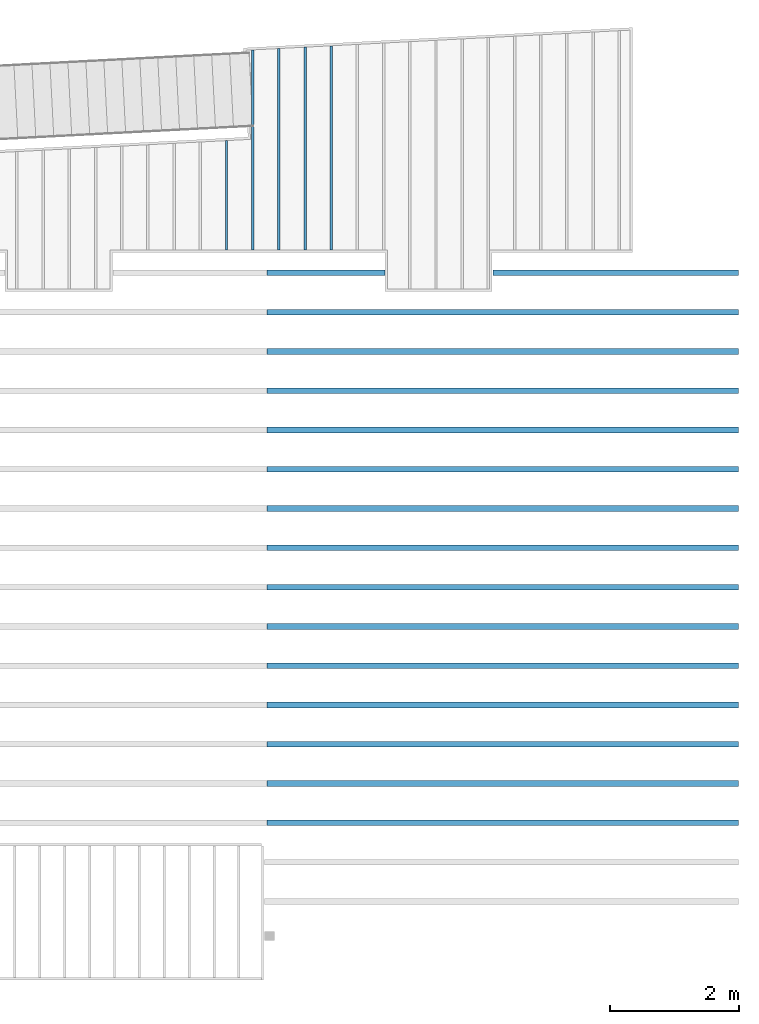
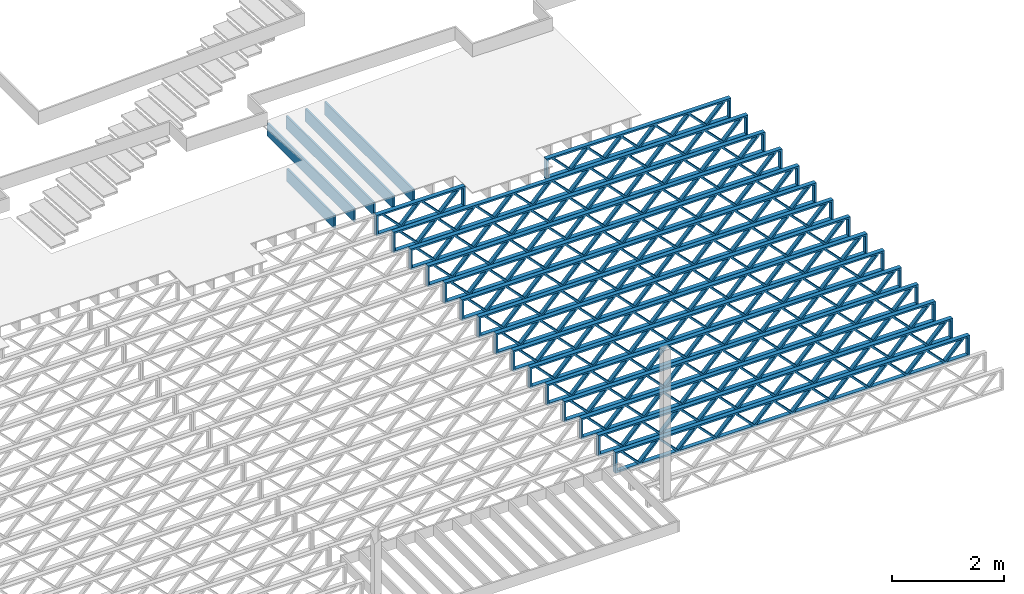
# One storey, part 11 of 23: 21 beams, 2 elements without a shape of their own.
"""IFC4 building model written with IfcOpenShell, lengths in feet."""

from ifc_helpers import new_model, entity, si_unit, converted_unit, derived_unit, direction, frame, frame_2d, origin, origin_2d_with_axis, place, context, subcontext, project, spatial, rectangle, extrude, source, transform, mapped, material, material_profile, profile_set, profile_usage, type_object, type_shapes, element, aggregate, save


model = new_model("IFC4")

# Units and contexts
model_context = context("Model", 3, precision=0.0001, world=origin(), true_north=direction((6.12303176911189e-17, 1.0)))
body_context = subcontext(model_context, "Body", "Model", "MODEL_VIEW")
ifc_project = project(units=[converted_unit("LENGTHUNIT", "FOOT", entity("IfcRatioMeasure", 0.3048), si_unit("LENGTHUNIT", "METRE"), dimensions=[1, 0, 0, 0, 0, 0, 0]), converted_unit("AREAUNIT", "SQUARE FOOT", entity("IfcRatioMeasure", 0.09290304), si_unit("AREAUNIT", "SQUARE_METRE"), dimensions=[2, 0, 0, 0, 0, 0, 0]), converted_unit("VOLUMEUNIT", "CUBIC FOOT", entity("IfcRatioMeasure", 0.028316846592), si_unit("VOLUMEUNIT", "CUBIC_METRE"), dimensions=[3, 0, 0, 0, 0, 0, 0]), converted_unit("PLANEANGLEUNIT", "DEGREE", entity("IfcRatioMeasure", 0.0174532925199433), si_unit("PLANEANGLEUNIT", "RADIAN"), dimensions=[0, 0, 0, 0, 0, 0, 0]), si_unit("MASSUNIT", "GRAM", prefix="KILO"), derived_unit("MASSDENSITYUNIT", [(si_unit("MASSUNIT", "GRAM", prefix="KILO"), 1), (si_unit("LENGTHUNIT", "METRE"), -3)]), derived_unit("MOMENTOFINERTIAUNIT", [(si_unit("LENGTHUNIT", "METRE"), 4)]), si_unit("TIMEUNIT", "SECOND"), si_unit("FREQUENCYUNIT", "HERTZ"), si_unit("THERMODYNAMICTEMPERATUREUNIT", "DEGREE_CELSIUS"), derived_unit("THERMALTRANSMITTANCEUNIT", [(si_unit("MASSUNIT", "GRAM", prefix="KILO"), 1), (si_unit("THERMODYNAMICTEMPERATUREUNIT", "KELVIN"), -1), (si_unit("TIMEUNIT", "SECOND"), -3)]), derived_unit("VOLUMETRICFLOWRATEUNIT", [(si_unit("LENGTHUNIT", "METRE"), 3), (si_unit("TIMEUNIT", "SECOND"), -1)]), si_unit("ELECTRICCURRENTUNIT", "AMPERE"), si_unit("ELECTRICVOLTAGEUNIT", "VOLT"), si_unit("POWERUNIT", "WATT"), si_unit("FORCEUNIT", "NEWTON"), si_unit("ILLUMINANCEUNIT", "LUX"), si_unit("LUMINOUSFLUXUNIT", "LUMEN"), si_unit("LUMINOUSINTENSITYUNIT", "CANDELA"), derived_unit("USERDEFINED", [(si_unit("MASSUNIT", "GRAM", prefix="KILO"), -1), (si_unit("LENGTHUNIT", "METRE"), -2), (si_unit("TIMEUNIT", "SECOND"), 3), (si_unit("LUMINOUSFLUXUNIT", "LUMEN"), 1)]), derived_unit("LINEARVELOCITYUNIT", [(si_unit("LENGTHUNIT", "METRE"), 1), (si_unit("TIMEUNIT", "SECOND"), -1)]), si_unit("PRESSUREUNIT", "PASCAL"), derived_unit("USERDEFINED", [(si_unit("LENGTHUNIT", "METRE"), -2), (si_unit("MASSUNIT", "GRAM", prefix="KILO"), 1), (si_unit("TIMEUNIT", "SECOND"), -2)]), derived_unit("LINEARFORCEUNIT", [(si_unit("MASSUNIT", "GRAM", prefix="KILO"), 1), (si_unit("LENGTHUNIT", "METRE"), 1), (si_unit("TIMEUNIT", "SECOND"), -2), (si_unit("LENGTHUNIT", "METRE"), -1)]), derived_unit("PLANARFORCEUNIT", [(si_unit("MASSUNIT", "GRAM", prefix="KILO"), 1), (si_unit("LENGTHUNIT", "METRE"), 1), (si_unit("TIMEUNIT", "SECOND"), -2), (si_unit("LENGTHUNIT", "METRE"), -2)])], contexts=[model_context])

# Site, building, storey
site_placement = place(None, origin())
site = spatial("IfcSite", under=ifc_project, at=site_placement, CompositionType="ELEMENT")
building_placement = place(site_placement, origin())
building = spatial("IfcBuilding", under=site, at=building_placement, CompositionType="ELEMENT")
storey_placement = place(building_placement, frame((0.0, 0.0, 10.8020833333333)))
storey = spatial("IfcBuildingStorey", under=building, at=storey_placement, Name="2ND FLOOR", CompositionType="ELEMENT", Elevation=10.8020833333333)

# Assembly, beams
assembly_1_placement = place(storey_placement, origin())
assembly_1 = element("IfcElementAssembly", 1, at=assembly_1_placement, inside=storey, Name="Structural Beam System:Structural Framing System", ObjectType="Structural Beam System:Structural Framing System", AssemblyPlace="NOTDEFINED", PredefinedType="BEAM_GRID")
ifc_material_1 = material(Name="WOOD TRUSS", Category="Materials")
ifc_material_profile_1 = material_profile(ifc_material_1, rectangle(XDim=1.73473973950632, YDim=0.125, at=frame_2d((-1.11022302462516e-16, 8.32667268468867e-17), x_axis=(1.0, 0.0))))
ifc_material_profile_2 = material_profile(ifc_material_1, rectangle(XDim=1.73473973950633, YDim=0.125, at=frame_2d((-1.11022302462516e-16, 8.32667268468867e-17), x_axis=(1.0, 0.0))))
ifc_material_profile_3 = material_profile(ifc_material_1, rectangle(XDim=1.73473973950632, YDim=0.125, at=frame_2d((-5.55111512312578e-17, 1.38777878078145e-16), x_axis=(1.0, 0.0))))
ifc_material_profile_4 = material_profile(ifc_material_1, rectangle(XDim=1.73473973950633, YDim=0.125, at=frame_2d((-1.11022302462516e-16, 8.32667268468867e-17), x_axis=(1.0, 0.0))))
ifc_material_profile_5 = material_profile(ifc_material_1, rectangle(XDim=1.73473973950632, YDim=0.125, at=frame_2d((-1.11022302462516e-16, 8.32667268468867e-17), x_axis=(1.0, 0.0))))
ifc_material_profile_6 = material_profile(ifc_material_1, rectangle(XDim=1.73473973950633, YDim=0.125, at=frame_2d((-2.77555756156289e-16, 3.05311331771918e-16), x_axis=(1.0, 0.0))))
ifc_material_profile_7 = material_profile(ifc_material_1, rectangle(XDim=1.73473973950632, YDim=0.124999999999999, at=frame_2d((-3.88578058618805e-16, -2.4980018054066e-16), x_axis=(1.0, 0.0))))
ifc_material_profile_8 = material_profile(ifc_material_1, rectangle(XDim=1.73473973950633, YDim=0.125, at=frame_2d((2.77555756156289e-16, -3.05311331771918e-16), x_axis=(1.0, 0.0))))
ifc_material_profile_9 = material_profile(ifc_material_1, rectangle(XDim=1.73473973950632, YDim=0.124999999999999, at=frame_2d((-1.11022302462516e-16, 8.32667268468867e-17), x_axis=(1.0, 0.0))))
ifc_material_profile_10 = material_profile(ifc_material_1, rectangle(XDim=1.73473973950633, YDim=0.125, at=origin_2d_with_axis()))
ifc_material_profile_11 = material_profile(ifc_material_1, rectangle(XDim=0.124999999999982, YDim=0.291666666666668, at=origin_2d_with_axis()))
ifc_material_profile_12 = material_profile(ifc_material_1, rectangle(XDim=0.124999999999932, YDim=0.291666666666664, at=origin_2d_with_axis()))
ifc_material_profile_13 = material_profile(ifc_material_1, rectangle(XDim=1.25000000000002, YDim=0.29166666666667, at=origin_2d_with_axis()))
ifc_material_profile_14 = material_profile(ifc_material_1, rectangle(XDim=1.25000000000004, YDim=0.291666666666667, at=origin_2d_with_axis()))
ifc_profile_set_1 = profile_set([ifc_material_profile_1, ifc_material_profile_2, ifc_material_profile_3, ifc_material_profile_4, ifc_material_profile_5, ifc_material_profile_6, ifc_material_profile_7, ifc_material_profile_8, ifc_material_profile_9, ifc_material_profile_10, ifc_material_profile_11, ifc_material_profile_12, ifc_material_profile_13, ifc_material_profile_14])
ifc_profile_usage_1 = profile_usage(ifc_profile_set_1, cardinal=8)
beam_type_1 = type_object("IfcBeamType", PredefinedType="BEAM", material=ifc_profile_set_1)
shared_shape_1 = source(origin(), body_context, "Body", "SweptSolid", [
    extrude(rectangle(XDim=1.73473973950632, YDim=0.125, at=frame_2d((-1.11022302462516e-16, 8.32667268468867e-17), x_axis=(1.0, 0.0))), frame((2.91681155651982, -0.145833333333334, 0.0), z_axis=(0.0, 1.0, 0.0), x_axis=(0.693383046997606, 0.0, 0.720569184836762)), (0.0, 0.0, 1.0), 0.291666666666667),
    extrude(rectangle(XDim=1.73473973950633, YDim=0.125, at=frame_2d((-1.11022302462516e-16, 8.32667268468867e-17), x_axis=(1.0, 0.0))), frame((1.66652568284655, -0.145833333333334, 0.0), z_axis=(0.0, 1.0, 0.0), x_axis=(0.69338304699761, 0.0, -0.720569184836758)), (0.0, 0.0, 1.0), 0.291666666666667),
    extrude(rectangle(XDim=1.73473973950632, YDim=0.125, at=frame_2d((-5.55111512312578e-17, 1.38777878078145e-16), x_axis=(1.0, 0.0))), frame((0.625142936836964, -0.145833333333334, 0.0), z_axis=(0.0, 1.0, 0.0), x_axis=(0.693383046997606, 0.0, 0.720569184836762)), (0.0, 0.0, 1.0), 0.291666666666667),
    extrude(rectangle(XDim=1.73473973950633, YDim=0.125, at=frame_2d((-1.11022302462516e-16, 8.32667268468867e-17), x_axis=(1.0, 0.0))), frame((-0.625142936836307, -0.145833333333334, 0.0), z_axis=(0.0, 1.0, 0.0), x_axis=(0.69338304699761, 0.0, -0.720569184836758)), (0.0, 0.0, 1.0), 0.291666666666667),
    extrude(rectangle(XDim=1.73473973950632, YDim=0.125, at=frame_2d((-1.11022302462516e-16, 8.32667268468867e-17), x_axis=(1.0, 0.0))), frame((-1.66652568284589, -0.145833333333334, 0.0), z_axis=(0.0, 1.0, 0.0), x_axis=(0.693383046997606, 0.0, 0.720569184836762)), (0.0, 0.0, 1.0), 0.291666666666667),
    extrude(rectangle(XDim=1.73473973950633, YDim=0.125, at=frame_2d((-2.77555756156289e-16, 3.05311331771918e-16), x_axis=(1.0, 0.0))), frame((-2.91681155651916, -0.145833333333334, 0.0), z_axis=(0.0, 1.0, 0.0), x_axis=(0.69338304699761, 0.0, -0.720569184836758)), (0.0, 0.0, 1.0), 0.291666666666667),
    extrude(rectangle(XDim=1.73473973950632, YDim=0.124999999999999, at=frame_2d((-3.88578058618805e-16, -2.4980018054066e-16), x_axis=(1.0, 0.0))), frame((5.20848017620267, -0.145833333333334, 0.0), z_axis=(0.0, 1.0, 0.0), x_axis=(0.693383046997607, 0.0, 0.720569184836761)), (0.0, 0.0, 1.0), 0.291666666666666),
    extrude(rectangle(XDim=1.73473973950633, YDim=0.125, at=frame_2d((2.77555756156289e-16, -3.05311331771918e-16), x_axis=(1.0, 0.0))), frame((3.9581943025294, -0.145833333333334, 0.0), z_axis=(0.0, 1.0, 0.0), x_axis=(0.69338304699761, 0.0, -0.720569184836758)), (0.0, 0.0, 1.0), 0.291666666666666),
    extrude(rectangle(XDim=1.73473973950632, YDim=0.124999999999999, at=frame_2d((-1.11022302462516e-16, 8.32667268468867e-17), x_axis=(1.0, 0.0))), frame((-3.95819430252874, -0.145833333333334, 0.0), z_axis=(0.0, 1.0, 0.0), x_axis=(0.693383046997606, 0.0, 0.720569184836762)), (0.0, 0.0, 1.0), 0.291666666666667),
    extrude(rectangle(XDim=1.73473973950633, YDim=0.125, at=origin_2d_with_axis()), frame((-5.20848017620202, -0.145833333333334, 0.0), z_axis=(0.0, 1.0, 0.0), x_axis=(0.69338304699761, 0.0, -0.720569184836758)), (0.0, 0.0, 1.0), 0.291666666666666),
    extrude(rectangle(XDim=0.124999999999982, YDim=0.291666666666668, at=origin_2d_with_axis()), frame((-6.25000390603229, 0.0, 0.687500000000054), z_axis=(1.0, 0.0, 0.0), x_axis=(0.0, 0.0, -1.0)), (0.0, 0.0, 1.0), 12.5000078120646),
    extrude(rectangle(XDim=0.124999999999932, YDim=0.291666666666664, at=origin_2d_with_axis()), frame((-6.25000390603208, 0.0, -0.687499999999984), z_axis=(1.0, 0.0, 0.0), x_axis=(0.0, 0.0, -1.0)), (0.0, 0.0, 1.0), 12.5000078120644),
    extrude(rectangle(XDim=1.25000000000002, YDim=0.29166666666667, at=origin_2d_with_axis()), frame((6.12500390603227, 0.0, 0.0), z_axis=(1.0, 0.0, 0.0), x_axis=(0.0, 0.0, -1.0)), (0.0, 0.0, 1.0), 0.12500000000002),
    extrude(rectangle(XDim=1.25000000000004, YDim=0.291666666666667, at=origin_2d_with_axis()), frame((-6.25000390603229, 0.0, 0.0), z_axis=(1.0, 0.0, 0.0), x_axis=(0.0, 0.0, -1.0)), (0.0, 0.0, 1.0), 0.125000000000023),
])
type_shapes(beam_type_1, [shared_shape_1])
beam_1_placement = place(assembly_1_placement, frame((-146.654823274369, 957.861934882651, -0.947916666657857), z_axis=(0.0, 0.0, 1.0), x_axis=(-1.0, 0.0, 0.0)))
beam_1 = element("IfcBeam", 2, at=beam_1_placement, type_object=beam_type_1, material=ifc_profile_usage_1, PredefinedType="BEAM", context=body_context, shape_type="MappedRepresentation", body=[
    mapped(shared_shape_1, transform((0.0, 0.0, 0.0), scale=1.0)),
])
ifc_profile_usage_2 = profile_usage(ifc_profile_set_1, cardinal=8)
beam_type_2 = type_object("IfcBeamType", PredefinedType="BEAM", material=ifc_profile_set_1)
shared_shape_2 = source(origin(), body_context, "Body", "SweptSolid", [
    extrude(rectangle(XDim=1.73473973950632, YDim=0.125, at=frame_2d((0.0, 1.66533453693773e-16), x_axis=(1.0, 0.0))), frame((1.95847576769603, -0.145833333333334, 0.0), z_axis=(0.0, 1.0, 0.0), x_axis=(0.693383046997606, 0.0, 0.720569184836762)), (0.0, 0.0, 1.0), 0.291666666666667),
    extrude(rectangle(XDim=1.73473973950633, YDim=0.125, at=frame_2d((-5.55111512312578e-17, 8.32667268468867e-17), x_axis=(1.0, 0.0))), frame((0.708189894022761, -0.145833333333334, 0.0), z_axis=(0.0, 1.0, 0.0), x_axis=(0.69338304699761, 0.0, -0.720569184836758)), (0.0, 0.0, 1.0), 0.291666666666667),
    extrude(rectangle(XDim=1.73473973950632, YDim=0.125, at=frame_2d((0.0, 1.66533453693773e-16), x_axis=(1.0, 0.0))), frame((-0.708189894022106, -0.145833333333334, 0.0), z_axis=(0.0, 1.0, 0.0), x_axis=(0.693383046997606, 0.0, 0.720569184836762)), (0.0, 0.0, 1.0), 0.291666666666667),
    extrude(rectangle(XDim=1.73473973950633, YDim=0.125, at=frame_2d((-2.22044604925031e-16, 2.22044604925031e-16), x_axis=(1.0, 0.0))), frame((-1.95847576769538, -0.145833333333334, 0.0), z_axis=(0.0, 1.0, 0.0), x_axis=(0.69338304699761, 0.0, -0.720569184836758)), (0.0, 0.0, 1.0), 0.291666666666666),
    extrude(rectangle(XDim=0.124999999999982, YDim=0.291666666666668, at=origin_2d_with_axis()), frame((-2.99999949752565, 0.0, 0.687500000000054), z_axis=(1.0, 0.0, 0.0), x_axis=(0.0, 0.0, -1.0)), (0.0, 0.0, 1.0), 5.9999989950513),
    extrude(rectangle(XDim=0.124999999999932, YDim=0.291666666666664, at=origin_2d_with_axis()), frame((-2.99999949752544, 0.0, -0.687499999999984), z_axis=(1.0, 0.0, 0.0), x_axis=(0.0, 0.0, -1.0)), (0.0, 0.0, 1.0), 5.99999899505109),
    extrude(rectangle(XDim=1.25000000000002, YDim=0.29166666666667, at=origin_2d_with_axis()), frame((2.87499949752563, 0.0, 0.0), z_axis=(1.0, 0.0, 0.0), x_axis=(0.0, 0.0, -1.0)), (0.0, 0.0, 1.0), 0.12500000000002),
    extrude(rectangle(XDim=1.25000000000004, YDim=0.291666666666667, at=origin_2d_with_axis()), frame((-2.99999949752565, 0.0, 0.0), z_axis=(1.0, 0.0, 0.0), x_axis=(0.0, 0.0, -1.0)), (0.0, 0.0, 1.0), 0.125000000000023),
])
type_shapes(beam_type_2, [shared_shape_2])
beam_2_placement = place(assembly_1_placement, frame((-161.40482765467, 957.861934882651, -0.947916666657848), z_axis=(0.0, 0.0, 1.0), x_axis=(-1.0, 0.0, 0.0)))
beam_2 = element("IfcBeam", 3, at=beam_2_placement, type_object=beam_type_2, material=ifc_profile_usage_2, PredefinedType="BEAM", context=body_context, shape_type="MappedRepresentation", body=[
    mapped(shared_shape_2, transform((0.0, 0.0, 0.0), scale=1.0)),
])
ifc_profile_usage_3 = profile_usage(ifc_profile_set_1, cardinal=8)
beam_type_3 = type_object("IfcBeamType", PredefinedType="BEAM", material=ifc_profile_set_1)
shared_shape_3 = source(origin(), body_context, "Body", "SweptSolid", [
    extrude(rectangle(XDim=1.73473973950632, YDim=0.124999999999999, at=frame_2d((5.55111512312578e-16, 7.21644966006352e-16), x_axis=(1.0, 0.0))), frame((8.37514585578398, -0.145833333333334, 0.0), z_axis=(0.0, 1.0, 0.0), x_axis=(0.693383046997606, 0.0, 0.720569184836762)), (0.0, 0.0, 1.0), 0.291666666666667),
    extrude(rectangle(XDim=1.73473973950633, YDim=0.125, at=origin_2d_with_axis()), frame((7.12485998211071, -0.145833333333334, 0.0), z_axis=(0.0, 1.0, 0.0), x_axis=(0.69338304699761, 0.0, -0.720569184836758)), (0.0, 0.0, 1.0), 0.291666666666666),
    extrude(rectangle(XDim=1.73473973950632, YDim=0.124999999999999, at=frame_2d((-1.11022302462516e-16, 8.32667268468867e-17), x_axis=(1.0, 0.0))), frame((5.79181154946831, -0.145833333333334, 0.0), z_axis=(0.0, 1.0, 0.0), x_axis=(0.693383046997606, 0.0, 0.720569184836762)), (0.0, 0.0, 1.0), 0.291666666666667),
    extrude(rectangle(XDim=1.73473973950633, YDim=0.125, at=origin_2d_with_axis()), frame((4.54152567579504, -0.145833333333334, 0.0), z_axis=(0.0, 1.0, 0.0), x_axis=(0.69338304699761, 0.0, -0.720569184836758)), (0.0, 0.0, 1.0), 0.291666666666666),
    extrude(rectangle(XDim=1.73473973950632, YDim=0.125, at=frame_2d((2.22044604925031e-16, 3.88578058618805e-16), x_axis=(1.0, 0.0))), frame((3.20847724315264, -0.145833333333334, 0.0), z_axis=(0.0, 1.0, 0.0), x_axis=(0.693383046997606, 0.0, 0.720569184836762)), (0.0, 0.0, 1.0), 0.291666666666667),
    extrude(rectangle(XDim=1.73473973950633, YDim=0.125, at=frame_2d((-1.11022302462516e-16, 8.32667268468867e-17), x_axis=(1.0, 0.0))), frame((1.95819136947937, -0.145833333333334, 0.0), z_axis=(0.0, 1.0, 0.0), x_axis=(0.69338304699761, 0.0, -0.720569184836758)), (0.0, 0.0, 1.0), 0.291666666666667),
    extrude(rectangle(XDim=1.73473973950632, YDim=0.125, at=frame_2d((-5.55111512312578e-17, 1.38777878078145e-16), x_axis=(1.0, 0.0))), frame((0.625142936836964, -0.145833333333334, 0.0), z_axis=(0.0, 1.0, 0.0), x_axis=(0.693383046997606, 0.0, 0.720569184836762)), (0.0, 0.0, 1.0), 0.291666666666667),
    extrude(rectangle(XDim=1.73473973950633, YDim=0.125, at=frame_2d((-1.11022302462516e-16, 8.32667268468867e-17), x_axis=(1.0, 0.0))), frame((-0.625142936836306, -0.145833333333334, 0.0), z_axis=(0.0, 1.0, 0.0), x_axis=(0.69338304699761, 0.0, -0.720569184836758)), (0.0, 0.0, 1.0), 0.291666666666667),
    extrude(rectangle(XDim=1.73473973950632, YDim=0.125, at=frame_2d((-1.11022302462516e-16, 8.32667268468867e-17), x_axis=(1.0, 0.0))), frame((-1.95819136947871, -0.145833333333334, 0.0), z_axis=(0.0, 1.0, 0.0), x_axis=(0.693383046997606, 0.0, 0.720569184836762)), (0.0, 0.0, 1.0), 0.291666666666667),
    extrude(rectangle(XDim=1.73473973950633, YDim=0.125, at=origin_2d_with_axis()), frame((-3.20847724315198, -0.145833333333334, 0.0), z_axis=(0.0, 1.0, 0.0), x_axis=(0.69338304699761, 0.0, -0.720569184836758)), (0.0, 0.0, 1.0), 0.291666666666667),
    extrude(rectangle(XDim=1.73473973950632, YDim=0.124999999999999, at=frame_2d((-1.11022302462516e-16, 8.32667268468867e-17), x_axis=(1.0, 0.0))), frame((-4.54152567579438, -0.145833333333334, 0.0), z_axis=(0.0, 1.0, 0.0), x_axis=(0.693383046997606, 0.0, 0.720569184836762)), (0.0, 0.0, 1.0), 0.291666666666667),
    extrude(rectangle(XDim=1.73473973950633, YDim=0.125, at=origin_2d_with_axis()), frame((-5.79181154946765, -0.145833333333334, 0.0), z_axis=(0.0, 1.0, 0.0), x_axis=(0.69338304699761, 0.0, -0.720569184836758)), (0.0, 0.0, 1.0), 0.291666666666666),
    extrude(rectangle(XDim=1.73473973950632, YDim=0.124999999999999, at=frame_2d((-1.11022302462516e-16, 8.32667268468867e-17), x_axis=(1.0, 0.0))), frame((-7.12485998211005, -0.145833333333334, 0.0), z_axis=(0.0, 1.0, 0.0), x_axis=(0.693383046997606, 0.0, 0.720569184836762)), (0.0, 0.0, 1.0), 0.291666666666667),
    extrude(rectangle(XDim=1.73473973950633, YDim=0.125, at=frame_2d((-2.77555756156289e-16, 3.05311331771918e-16), x_axis=(1.0, 0.0))), frame((-8.37514585578332, -0.145833333333334, 0.0), z_axis=(0.0, 1.0, 0.0), x_axis=(0.69338304699761, 0.0, -0.720569184836758)), (0.0, 0.0, 1.0), 0.291666666666666),
    extrude(rectangle(XDim=1.73473973950632, YDim=0.125, at=frame_2d((-7.21644966006352e-16, -5.55111512312578e-16), x_axis=(1.0, 0.0))), frame((10.9584801620997, -0.145833333333334, 0.0), z_axis=(0.0, 1.0, 0.0), x_axis=(0.693383046997606, 0.0, 0.720569184836762)), (0.0, 0.0, 1.0), 0.291666666666667),
    extrude(rectangle(XDim=1.73473973950633, YDim=0.125, at=origin_2d_with_axis()), frame((9.70819428842638, -0.145833333333334, 0.0), z_axis=(0.0, 1.0, 0.0), x_axis=(0.69338304699761, 0.0, -0.720569184836758)), (0.0, 0.0, 1.0), 0.291666666666666),
    extrude(rectangle(XDim=1.73473973950632, YDim=0.125, at=frame_2d((-5.55111512312578e-17, 8.32667268468867e-17), x_axis=(1.0, 0.0))), frame((-9.70819428842572, -0.145833333333334, 0.0), z_axis=(0.0, 1.0, 0.0), x_axis=(0.693383046997606, 0.0, 0.720569184836762)), (0.0, 0.0, 1.0), 0.291666666666667),
    extrude(rectangle(XDim=1.73473973950633, YDim=0.125, at=origin_2d_with_axis()), frame((-10.958480162099, -0.145833333333334, 0.0), z_axis=(0.0, 1.0, 0.0), x_axis=(0.69338304699761, 0.0, -0.720569184836758)), (0.0, 0.0, 1.0), 0.291666666666666),
    extrude(rectangle(XDim=0.124999999999982, YDim=0.291666666666668, at=origin_2d_with_axis()), frame((-12.0000038919293, 0.0, 0.687500000000054), z_axis=(1.0, 0.0, 0.0), x_axis=(0.0, 0.0, -1.0)), (0.0, 0.0, 1.0), 24.0000077838585),
    extrude(rectangle(XDim=0.124999999999932, YDim=0.291666666666664, at=origin_2d_with_axis()), frame((-12.0000038919291, 0.0, -0.687499999999984), z_axis=(1.0, 0.0, 0.0), x_axis=(0.0, 0.0, -1.0)), (0.0, 0.0, 1.0), 24.0000077838583),
    extrude(rectangle(XDim=1.25000000000002, YDim=0.29166666666667, at=origin_2d_with_axis()), frame((11.8750038919292, 0.0, 0.0), z_axis=(1.0, 0.0, 0.0), x_axis=(0.0, 0.0, -1.0)), (0.0, 0.0, 1.0), 0.12500000000002),
    extrude(rectangle(XDim=1.25000000000004, YDim=0.291666666666667, at=origin_2d_with_axis()), frame((-12.0000038919293, 0.0, 0.0), z_axis=(1.0, 0.0, 0.0), x_axis=(0.0, 0.0, -1.0)), (0.0, 0.0, 1.0), 0.125000000000023),
])
type_shapes(beam_type_3, [shared_shape_3])
beam_3_placement = place(assembly_1_placement, frame((-152.404823260266, 955.861934882651, -0.947916666657859), z_axis=(0.0, 0.0, 1.0), x_axis=(-1.0, 0.0, 0.0)))
beam_3 = element("IfcBeam", 4, at=beam_3_placement, type_object=beam_type_3, material=ifc_profile_usage_3, PredefinedType="BEAM", context=body_context, shape_type="MappedRepresentation", body=[
    mapped(shared_shape_3, transform((0.0, 0.0, 0.0), scale=1.0)),
])
ifc_profile_usage_4 = profile_usage(ifc_profile_set_1, cardinal=8)
beam_4_placement = place(assembly_1_placement, frame((-152.404823260266, 953.861934882651, -0.947916666657859), z_axis=(0.0, 0.0, 1.0), x_axis=(-1.0, 0.0, 0.0)))
beam_4 = element("IfcBeam", 5, at=beam_4_placement, type_object=beam_type_3, material=ifc_profile_usage_4, PredefinedType="BEAM", context=body_context, shape_type="MappedRepresentation", body=[
    mapped(shared_shape_3, transform((0.0, 0.0, 0.0), scale=1.0)),
])
ifc_profile_usage_5 = profile_usage(ifc_profile_set_1, cardinal=8)
beam_5_placement = place(assembly_1_placement, frame((-152.404823260266, 951.861934882651, -0.947916666657859), z_axis=(0.0, 0.0, 1.0), x_axis=(-1.0, 0.0, 0.0)))
beam_5 = element("IfcBeam", 6, at=beam_5_placement, type_object=beam_type_3, material=ifc_profile_usage_5, PredefinedType="BEAM", context=body_context, shape_type="MappedRepresentation", body=[
    mapped(shared_shape_3, transform((0.0, 0.0, 0.0), scale=1.0)),
])
ifc_profile_usage_6 = profile_usage(ifc_profile_set_1, cardinal=8)
beam_6_placement = place(assembly_1_placement, frame((-152.404823260266, 949.861934882651, -0.947916666657859), z_axis=(0.0, 0.0, 1.0), x_axis=(-1.0, 0.0, 0.0)))
beam_6 = element("IfcBeam", 7, at=beam_6_placement, type_object=beam_type_3, material=ifc_profile_usage_6, PredefinedType="BEAM", context=body_context, shape_type="MappedRepresentation", body=[
    mapped(shared_shape_3, transform((0.0, 0.0, 0.0), scale=1.0)),
])
ifc_profile_usage_7 = profile_usage(ifc_profile_set_1, cardinal=8)
beam_7_placement = place(assembly_1_placement, frame((-152.404823260266, 947.861934882651, -0.947916666657859), z_axis=(0.0, 0.0, 1.0), x_axis=(-1.0, 0.0, 0.0)))
beam_7 = element("IfcBeam", 8, at=beam_7_placement, type_object=beam_type_3, material=ifc_profile_usage_7, PredefinedType="BEAM", context=body_context, shape_type="MappedRepresentation", body=[
    mapped(shared_shape_3, transform((0.0, 0.0, 0.0), scale=1.0)),
])
ifc_profile_usage_8 = profile_usage(ifc_profile_set_1, cardinal=8)
beam_8_placement = place(assembly_1_placement, frame((-152.404823260266, 945.861934882651, -0.947916666657859), z_axis=(0.0, 0.0, 1.0), x_axis=(-1.0, 0.0, 0.0)))
beam_8 = element("IfcBeam", 9, at=beam_8_placement, type_object=beam_type_3, material=ifc_profile_usage_8, PredefinedType="BEAM", context=body_context, shape_type="MappedRepresentation", body=[
    mapped(shared_shape_3, transform((0.0, 0.0, 0.0), scale=1.0)),
])
ifc_profile_usage_9 = profile_usage(ifc_profile_set_1, cardinal=8)
beam_9_placement = place(assembly_1_placement, frame((-152.404823260266, 943.861934882651, -0.947916666657859), z_axis=(0.0, 0.0, 1.0), x_axis=(-1.0, 0.0, 0.0)))
beam_9 = element("IfcBeam", 10, at=beam_9_placement, type_object=beam_type_3, material=ifc_profile_usage_9, PredefinedType="BEAM", context=body_context, shape_type="MappedRepresentation", body=[
    mapped(shared_shape_3, transform((0.0, 0.0, 0.0), scale=1.0)),
])
ifc_profile_usage_10 = profile_usage(ifc_profile_set_1, cardinal=8)
beam_10_placement = place(assembly_1_placement, frame((-152.404823260266, 941.861934882651, -0.947916666657859), z_axis=(0.0, 0.0, 1.0), x_axis=(-1.0, 0.0, 0.0)))
beam_10 = element("IfcBeam", 11, at=beam_10_placement, type_object=beam_type_3, material=ifc_profile_usage_10, PredefinedType="BEAM", context=body_context, shape_type="MappedRepresentation", body=[
    mapped(shared_shape_3, transform((0.0, 0.0, 0.0), scale=1.0)),
])
ifc_profile_usage_11 = profile_usage(ifc_profile_set_1, cardinal=8)
beam_11_placement = place(assembly_1_placement, frame((-152.404823260266, 939.861934882651, -0.947916666657859), z_axis=(0.0, 0.0, 1.0), x_axis=(-1.0, 0.0, 0.0)))
beam_11 = element("IfcBeam", 12, at=beam_11_placement, type_object=beam_type_3, material=ifc_profile_usage_11, PredefinedType="BEAM", context=body_context, shape_type="MappedRepresentation", body=[
    mapped(shared_shape_3, transform((0.0, 0.0, 0.0), scale=1.0)),
])
ifc_profile_usage_12 = profile_usage(ifc_profile_set_1, cardinal=8)
beam_12_placement = place(assembly_1_placement, frame((-152.404823260266, 937.861934882651, -0.947916666657859), z_axis=(0.0, 0.0, 1.0), x_axis=(-1.0, 0.0, 0.0)))
beam_12 = element("IfcBeam", 13, at=beam_12_placement, type_object=beam_type_3, material=ifc_profile_usage_12, PredefinedType="BEAM", context=body_context, shape_type="MappedRepresentation", body=[
    mapped(shared_shape_3, transform((0.0, 0.0, 0.0), scale=1.0)),
])
ifc_profile_usage_13 = profile_usage(ifc_profile_set_1, cardinal=8)
beam_13_placement = place(assembly_1_placement, frame((-152.404823260266, 935.861934882651, -0.947916666657859), z_axis=(0.0, 0.0, 1.0), x_axis=(-1.0, 0.0, 0.0)))
beam_13 = element("IfcBeam", 14, at=beam_13_placement, type_object=beam_type_3, material=ifc_profile_usage_13, PredefinedType="BEAM", context=body_context, shape_type="MappedRepresentation", body=[
    mapped(shared_shape_3, transform((0.0, 0.0, 0.0), scale=1.0)),
])
ifc_profile_usage_14 = profile_usage(ifc_profile_set_1, cardinal=8)
beam_14_placement = place(assembly_1_placement, frame((-152.404823260266, 933.861934882651, -0.947916666657859), z_axis=(0.0, 0.0, 1.0), x_axis=(-1.0, 0.0, 0.0)))
beam_14 = element("IfcBeam", 15, at=beam_14_placement, type_object=beam_type_3, material=ifc_profile_usage_14, PredefinedType="BEAM", context=body_context, shape_type="MappedRepresentation", body=[
    mapped(shared_shape_3, transform((0.0, 0.0, 0.0), scale=1.0)),
])
ifc_profile_usage_15 = profile_usage(ifc_profile_set_1, cardinal=8)
beam_15_placement = place(assembly_1_placement, frame((-152.404823260266, 931.861934882651, -0.947916666657859), z_axis=(0.0, 0.0, 1.0), x_axis=(-1.0, 0.0, 0.0)))
beam_15 = element("IfcBeam", 16, at=beam_15_placement, type_object=beam_type_3, material=ifc_profile_usage_15, PredefinedType="BEAM", context=body_context, shape_type="MappedRepresentation", body=[
    mapped(shared_shape_3, transform((0.0, 0.0, 0.0), scale=1.0)),
])
ifc_profile_usage_16 = profile_usage(ifc_profile_set_1, cardinal=8)
beam_16_placement = place(assembly_1_placement, frame((-152.404823260266, 929.861934882651, -0.947916666657859), z_axis=(0.0, 0.0, 1.0), x_axis=(-1.0, 0.0, 0.0)))
beam_16 = element("IfcBeam", 17, at=beam_16_placement, type_object=beam_type_3, material=ifc_profile_usage_16, PredefinedType="BEAM", context=body_context, shape_type="MappedRepresentation", body=[
    mapped(shared_shape_3, transform((0.0, 0.0, 0.0), scale=1.0)),
])
aggregate(assembly_1, [beam_1, beam_2, beam_3, beam_4, beam_5, beam_6, beam_7, beam_8, beam_9, beam_10, beam_11, beam_12, beam_13, beam_14, beam_15, beam_16])

assembly_2_placement = place(storey_placement, origin())
assembly_2 = element("IfcElementAssembly", 18, at=assembly_2_placement, inside=storey, Name="Structural Beam System:Structural Framing System", ObjectType="Structural Beam System:Structural Framing System", AssemblyPlace="NOTDEFINED", PredefinedType="BEAM_GRID")
ifc_material_2 = material(Category="Materials")
ifc_material_profile_15 = material_profile(ifc_material_2, rectangle(XDim=0.9375, YDim=0.125000000000011, at=origin_2d_with_axis()))
ifc_profile_set_2 = profile_set([ifc_material_profile_15])
ifc_profile_usage_17 = profile_usage(ifc_profile_set_2, cardinal=8)
beam_type_4 = type_object("IfcBeamType", PredefinedType="BEAM", material=ifc_profile_set_2)
shared_shape_4 = source(origin(), body_context, "Body", "SweptSolid", [
    extrude(rectangle(XDim=0.9375, YDim=0.125000000000011, at=origin_2d_with_axis()), frame((-2.78269382036365, 0.0, 0.0), z_axis=(1.0, 0.0, 0.0), x_axis=(0.0, 0.0, -1.0)), (0.0, 0.0, 1.0), 5.56538764072729),
])
type_shapes(beam_type_4, [shared_shape_4])
beam_17_placement = place(assembly_2_placement, frame((-166.467327152129, 961.811296133637, -0.729166666666744), z_axis=(0.0, 0.0, 1.0), x_axis=(0.0, 1.0, 0.0)))
beam_17 = element("IfcBeam", 19, at=beam_17_placement, type_object=beam_type_4, material=ifc_profile_usage_17, PredefinedType="BEAM", context=body_context, shape_type="MappedRepresentation", body=[
    mapped(shared_shape_4, transform((0.0, 0.0, 0.0), scale=1.0)),
])
ifc_profile_usage_18 = profile_usage(ifc_profile_set_2, cardinal=8)
beam_type_5 = type_object("IfcBeamType", PredefinedType="BEAM", material=ifc_profile_set_2)
shared_shape_5 = source(origin(), body_context, "Body", "SweptSolid", [
    extrude(rectangle(XDim=0.9375, YDim=0.125000000000011, at=origin_2d_with_axis()), frame((-5.12287476158264, 0.0, 0.0), z_axis=(1.0, 0.0, 0.0), x_axis=(0.0, 0.0, -1.0)), (0.0, 0.0, 1.0), 10.1798882653351),
])
type_shapes(beam_type_5, [shared_shape_5])
beam_18_placement = place(assembly_2_placement, frame((-165.133993818795, 964.151477409859, -0.729166666666744), z_axis=(0.0, 0.0, 1.0), x_axis=(0.0, 1.0, 0.0)))
beam_18 = element("IfcBeam", 20, at=beam_18_placement, type_object=beam_type_5, material=ifc_profile_usage_18, PredefinedType="BEAM", context=body_context, shape_type="MappedRepresentation", body=[
    mapped(shared_shape_5, transform((0.0, 0.0, 0.0), scale=1.0)),
])
ifc_profile_usage_19 = profile_usage(ifc_profile_set_2, cardinal=8)
beam_type_6 = type_object("IfcBeamType", PredefinedType="BEAM", material=ifc_profile_set_2)
shared_shape_6 = source(origin(), body_context, "Body", "SweptSolid", [
    extrude(rectangle(XDim=0.9375, YDim=0.125000000000011, at=origin_2d_with_axis()), frame((-5.12652022779071, 0.0, 0.0), z_axis=(1.0, 0.0, 0.0), x_axis=(0.0, 0.0, -1.0)), (0.0, 0.0, 1.0), 10.2530404555814),
])
type_shapes(beam_type_6, [shared_shape_6])
beam_19_placement = place(assembly_2_placement, frame((-163.800660485462, 964.155123211069, -0.729166666666744), z_axis=(0.0, 0.0, 1.0), x_axis=(0.0, 1.0, 0.0)))
beam_19 = element("IfcBeam", 21, at=beam_19_placement, type_object=beam_type_6, material=ifc_profile_usage_19, PredefinedType="BEAM", context=body_context, shape_type="MappedRepresentation", body=[
    mapped(shared_shape_6, transform((0.0, 0.0, 0.0), scale=1.0)),
])
ifc_profile_usage_20 = profile_usage(ifc_profile_set_2, cardinal=8)
beam_type_7 = type_object("IfcBeamType", PredefinedType="BEAM", material=ifc_profile_set_2)
shared_shape_7 = source(origin(), body_context, "Body", "SweptSolid", [
    extrude(rectangle(XDim=0.9375, YDim=0.125000000000011, at=origin_2d_with_axis()), frame((-5.16145857981161, 0.0, 0.0), z_axis=(1.0, 0.0, 0.0), x_axis=(0.0, 0.0, -1.0)), (0.0, 0.0, 1.0), 10.3229171596232),
])
type_shapes(beam_type_7, [shared_shape_7])
beam_20_placement = place(assembly_2_placement, frame((-162.467327152129, 964.190061898092, -0.729166666666744), z_axis=(0.0, 0.0, 1.0), x_axis=(0.0, 1.0, 0.0)))
beam_20 = element("IfcBeam", 22, at=beam_20_placement, type_object=beam_type_7, material=ifc_profile_usage_20, PredefinedType="BEAM", context=body_context, shape_type="MappedRepresentation", body=[
    mapped(shared_shape_7, transform((0.0, 0.0, 0.0), scale=1.0)),
])
ifc_profile_usage_21 = profile_usage(ifc_profile_set_2, cardinal=8)
beam_type_8 = type_object("IfcBeamType", PredefinedType="BEAM", material=ifc_profile_set_2)
shared_shape_8 = source(origin(), body_context, "Body", "SweptSolid", [
    extrude(rectangle(XDim=0.9375, YDim=0.125000000000011, at=origin_2d_with_axis()), frame((-5.19639693183245, 0.0, 0.0), z_axis=(1.0, 0.0, 0.0), x_axis=(0.0, 0.0, -1.0)), (0.0, 0.0, 1.0), 10.3927938636649),
])
type_shapes(beam_type_8, [shared_shape_8])
beam_21_placement = place(assembly_2_placement, frame((-161.133993818795, 964.225000585116, -0.729166666666744), z_axis=(0.0, 0.0, 1.0), x_axis=(0.0, 1.0, 0.0)))
beam_21 = element("IfcBeam", 23, at=beam_21_placement, type_object=beam_type_8, material=ifc_profile_usage_21, PredefinedType="BEAM", context=body_context, shape_type="MappedRepresentation", body=[
    mapped(shared_shape_8, transform((0.0, 0.0, 0.0), scale=1.0)),
])
aggregate(assembly_2, [beam_17, beam_18, beam_19, beam_20, beam_21])

save(model, "model.ifc")
